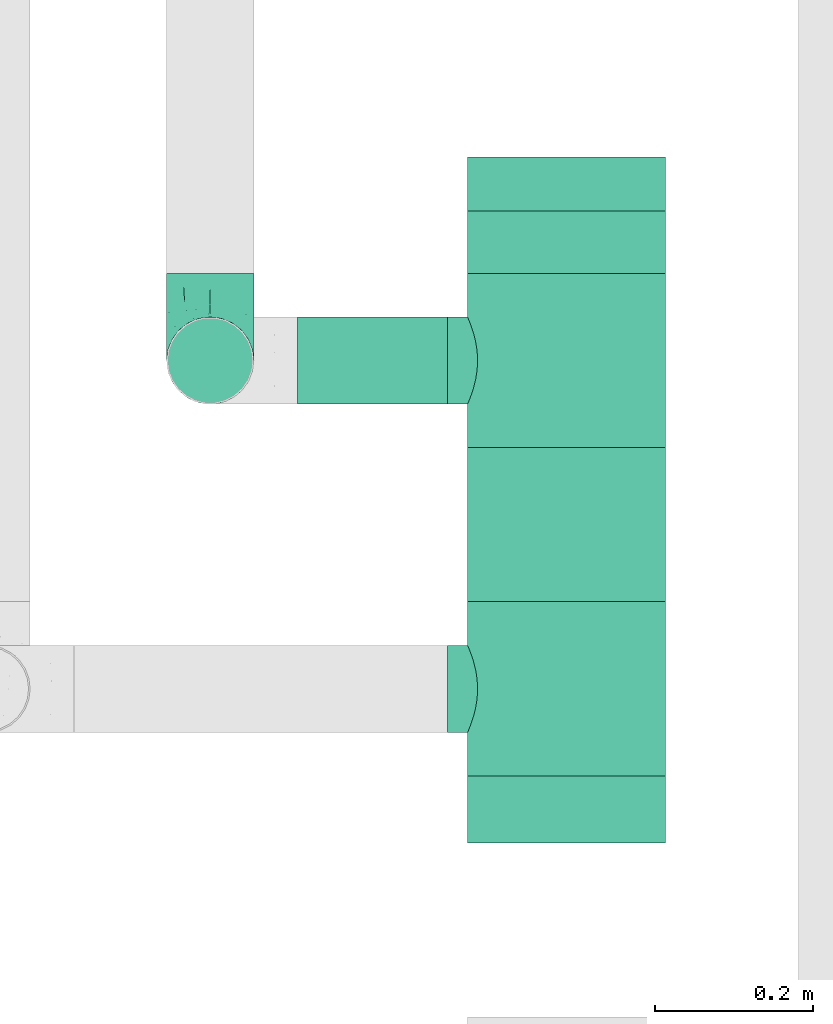
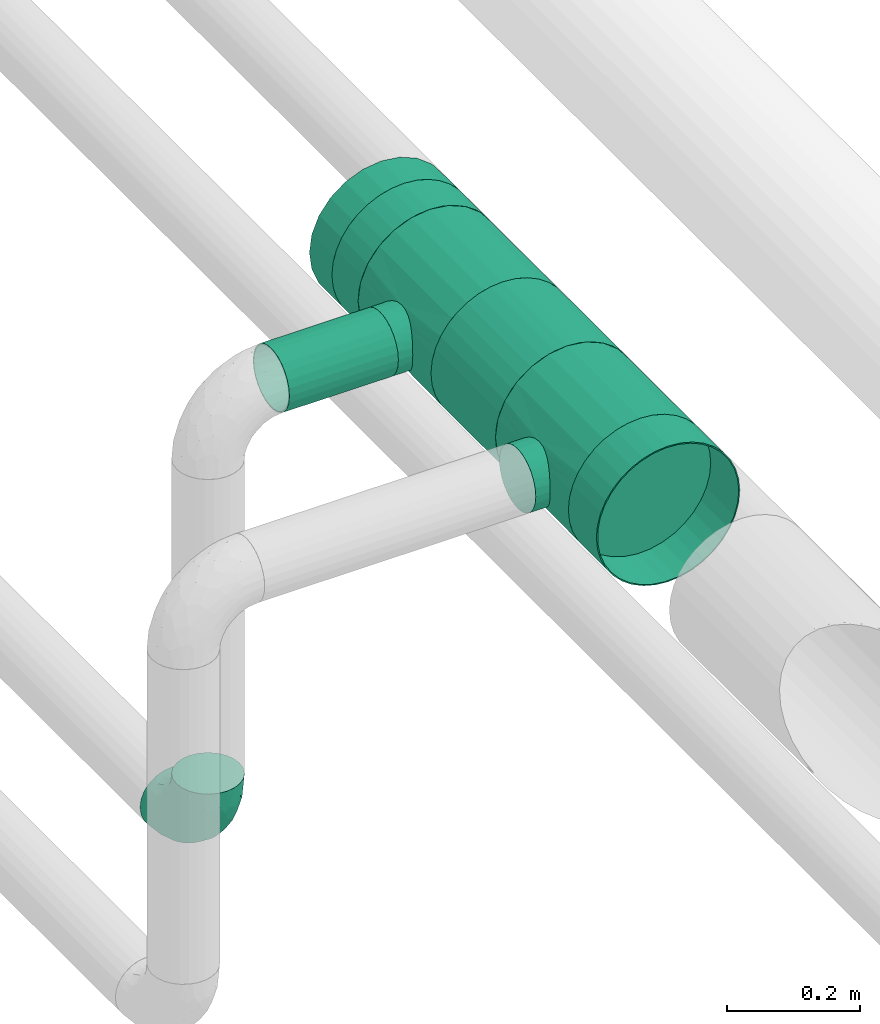
# One storey, part 42 of 91: 4 flow fittings, 4 flow segments.
"""IFC2X3 building model written with IfcOpenShell, lengths in millimetres."""

from ifc_helpers import new_model, entity, si_unit, converted_unit, derived_unit, direction, frame, origin_with_axes, origin_2d_with_axis, place, context, subcontext, project, spatial, hollow_circle, extrude, open_shell, surface_model, source, transform, mapped, material, layer, layer_set, layer_usage, type_object, element, save


model = new_model("IFC2X3")

# Units and contexts
model_context = context("Model", 3, precision=1e-05, world=origin_with_axes(), true_north=direction((0.0, 1.0)))
body_context = subcontext(model_context, "Body", "Model", "MODEL_VIEW")
ifc_project = project(units=[si_unit("AREAUNIT", "SQUARE_METRE"), si_unit("VOLUMEUNIT", "CUBIC_METRE", prefix="DECI"), si_unit("TIMEUNIT", "SECOND"), si_unit("THERMODYNAMICTEMPERATUREUNIT", "DEGREE_CELSIUS"), si_unit("PRESSUREUNIT", "PASCAL"), si_unit("MASSUNIT", "GRAM", prefix="KILO"), si_unit("LENGTHUNIT", "METRE", prefix="MILLI"), si_unit("POWERUNIT", "WATT"), si_unit("ELECTRICCURRENTUNIT", "AMPERE"), si_unit("ELECTRICVOLTAGEUNIT", "VOLT"), derived_unit("VOLUMETRICFLOWRATEUNIT", [(si_unit("VOLUMEUNIT", "CUBIC_METRE", prefix="DECI"), 1), (si_unit("TIMEUNIT", "SECOND"), -1)]), derived_unit("LINEARVELOCITYUNIT", [(si_unit("LENGTHUNIT", "METRE"), 1), (si_unit("TIMEUNIT", "SECOND"), -1)]), derived_unit("MASSDENSITYUNIT", [(si_unit("MASSUNIT", "GRAM", prefix="KILO"), 1), (si_unit("VOLUMEUNIT", "CUBIC_METRE"), -1)]), converted_unit("PLANEANGLEUNIT", "DEGREE", entity("IfcRatioMeasure", 0.01745), si_unit("PLANEANGLEUNIT", "RADIAN"), dimensions=[0, 0, 0, 0, 0, 0, 0])], contexts=[model_context])

# Site, building, storey
site_placement = place(None, origin_with_axes())
site = spatial("IfcSite", under=ifc_project, at=site_placement, CompositionType="ELEMENT")
building_placement = place(site_placement, origin_with_axes())
building = spatial("IfcBuilding", under=site, at=building_placement, Name="mc-building", CompositionType="ELEMENT")
storey_placement = place(building_placement, frame((0.0, 0.0, 8700.0), z_axis=(0.0, 0.0, 1.0), x_axis=(1.0, 0.0, 0.0)))
storey = spatial("IfcBuildingStorey", under=building, at=storey_placement, CompositionType="ELEMENT", Elevation=8700.0)

# Flow fittings
duct_fitting_type_1 = type_object("IfcDuctFittingType", PredefinedType="JUNCTION")
shared_shape_1 = source(origin_with_axes(), body_context, "Body", "SurfaceModel", [
    surface_model("IfcShellBasedSurfaceModel", [(0.0, -150.0, -55.0), (14.23505, -150.0, -53.12592), (-14.23505, -150.0, -53.12592), (-53.12592, -150.0, 14.23505), (-27.5, -150.0, -47.63139), (-47.63139, -150.0, -27.5), (-38.89087, -150.0, -38.89087), (55.0, -150.0, 0.0), (53.12592, -150.0, 14.23505), (38.89087, -150.0, -38.89087), (27.5, -150.0, -47.63139), (53.12592, -150.0, -14.23505), (47.63139, -150.0, -27.5), (-53.12592, -150.0, -14.23505), (-47.63139, -150.0, 27.5), (-38.89087, -150.0, 38.89087), (14.23505, -150.0, 53.12592), (-27.5, -150.0, 47.63139), (-14.23505, -150.0, 53.12592), (47.63139, -150.0, 27.5), (38.89087, -150.0, 38.89087), (27.5, -150.0, 47.63139), (0.0, -150.0, 55.0), (-55.0, -150.0, 0.0), (0.0, -112.24973, 55.0), (-12.37766, -112.9301, 53.58912), (-24.01261, -114.7894, 49.48125), (-34.33641, -117.38394, 42.96523), (-42.94114, -120.18295, 34.36653), (-49.47537, -122.66953, 24.02472), (-53.59142, -124.38666, 12.36769), (-55.0, -125.0, 0.0), (-49.46959, -122.66719, -24.03663), (-42.93393, -120.18037, -34.37554), (-53.588, -124.38519, -12.38248), (-34.32718, -117.38124, -42.9726), (-24.00081, -114.78693, -49.48698), (-12.36238, -112.92842, -53.59265), (0.0, -112.24973, -55.0), (12.37766, -112.9301, -53.58912), (24.01261, -114.7894, -49.48125), (34.33641, -117.38394, -42.96523), (42.94114, -120.18295, -34.36653), (49.47537, -122.66953, -24.02472), (53.59142, -124.38666, -12.36769), (55.0, -125.0, 0.0), (49.47537, -122.66953, 24.02472), (42.94114, -120.18295, 34.36653), (53.59142, -124.38666, 12.36769), (34.33641, -117.38394, 42.96523), (24.01261, -114.7894, 49.48125), (12.37766, -112.9301, 53.58912), (-110.0, 0.0, -125.0), (-110.0, -32.35238, -120.74073), (-110.0, 32.35238, -120.74073), (-110.0, 120.74073, 32.35238), (-110.0, 62.5, -108.25318), (-110.0, 88.38835, -88.38835), (-110.0, 108.25318, -62.5), (-110.0, -125.0, 0.0), (-110.0, -120.74073, 32.35238), (-110.0, -88.38835, -88.38835), (-110.0, -62.5, -108.25318), (-110.0, -120.74073, -32.35238), (-110.0, -108.25318, -62.5), (-110.0, 120.74073, -32.35238), (-110.0, 108.25318, 62.5), (-110.0, 62.5, 108.25318), (-110.0, 32.35238, 120.74073), (-110.0, 88.38835, 88.38835), (-110.0, 0.0, 125.0), (-110.0, -108.25318, 62.5), (-110.0, -88.38835, 88.38835), (-110.0, -32.35238, 120.74073), (-110.0, -62.5, 108.25318), (-110.0, 125.0, 0.0), (110.0, 32.35238, -120.74073), (110.0, 125.0, 0.0), (110.0, 0.0, -125.0), (110.0, 62.5, -108.25318), (110.0, 88.38835, -88.38835), (110.0, 108.25318, -62.5), (110.0, -88.38835, -88.38835), (110.0, -120.74073, 32.35238), (110.0, -62.5, -108.25318), (110.0, -32.35238, -120.74073), (110.0, -108.25318, -62.5), (110.0, -120.74073, -32.35238), (110.0, -125.0, 0.0), (110.0, 120.74073, -32.35238), (110.0, 108.25318, 62.5), (110.0, 120.74073, 32.35238), (110.0, 88.38835, 88.38835), (110.0, 62.5, 108.25318), (110.0, 32.35238, 120.74073), (110.0, -62.5, 108.25318), (110.0, -108.25318, 62.5), (110.0, -88.38835, 88.38835), (110.0, -32.35238, 120.74073), (110.0, 0.0, 125.0), (-110.0, -122.87036, -16.17619), (110.0, -114.49695, -47.42619), (-110.0, -114.49695, -47.42619), (110.0, -122.87036, -16.17619), (110.0, -122.87036, 16.17619), (110.0, -114.49695, 47.42619), (-110.0, -122.87036, 16.17619), (-110.0, -114.49695, 47.42619)], [open_shell([[[0, 1, 2]], [[2, 3, 4]], [[5, 6, 3]], [[6, 4, 3]], [[2, 7, 8]], [[9, 7, 10]], [[1, 10, 7]], [[11, 7, 12]], [[9, 12, 7]], [[7, 2, 1]], [[5, 3, 13]], [[2, 14, 3]], [[2, 15, 14]], [[2, 16, 17]], [[17, 15, 2]], [[16, 18, 17]], [[2, 8, 19]], [[2, 19, 20]], [[2, 20, 21]], [[16, 2, 21]], [[16, 22, 18]], [[23, 13, 3]], [[22, 24, 25]], [[18, 25, 26]], [[22, 25, 18]], [[17, 27, 15]], [[17, 18, 26]], [[27, 17, 26]], [[28, 29, 14]], [[30, 31, 23]], [[29, 30, 3]], [[15, 28, 14]], [[3, 14, 29]], [[23, 3, 30]], [[28, 15, 27]], [[32, 33, 5]], [[34, 32, 13]], [[31, 34, 23]], [[23, 34, 13]], [[32, 5, 13]], [[33, 6, 5]], [[4, 35, 36]], [[36, 37, 2]], [[38, 0, 37]], [[4, 6, 35]], [[2, 4, 36]], [[37, 0, 2]], [[35, 6, 33]], [[0, 38, 39]], [[1, 39, 40]], [[0, 39, 1]], [[10, 41, 9]], [[10, 1, 40]], [[41, 10, 40]], [[42, 43, 12]], [[44, 45, 7]], [[43, 44, 11]], [[9, 42, 12]], [[7, 11, 44]], [[43, 11, 12]], [[42, 9, 41]], [[46, 47, 19]], [[48, 46, 8]], [[45, 48, 7]], [[7, 48, 8]], [[46, 19, 8]], [[47, 20, 19]], [[21, 49, 50]], [[50, 51, 16]], [[24, 22, 51]], [[20, 49, 21]], [[16, 21, 50]], [[22, 16, 51]], [[49, 20, 47]], [[52, 53, 54]], [[54, 55, 56]], [[57, 55, 58]], [[56, 55, 57]], [[54, 59, 60]], [[61, 59, 62]], [[54, 53, 62]], [[63, 59, 64]], [[61, 64, 59]], [[62, 59, 54]], [[65, 58, 55]], [[66, 55, 54]], [[67, 66, 54]], [[67, 54, 68]], [[69, 66, 67]], [[70, 68, 54]], [[60, 71, 54]], [[71, 72, 54]], [[73, 70, 74]], [[72, 74, 70]], [[54, 72, 70]], [[75, 65, 55]], [[76, 77, 78]], [[79, 77, 76]], [[80, 81, 77]], [[80, 77, 79]], [[82, 78, 83]], [[78, 82, 84]], [[84, 85, 78]], [[86, 83, 87]], [[86, 82, 83]], [[88, 87, 83]], [[77, 81, 89]], [[90, 78, 91]], [[78, 90, 92]], [[93, 94, 78]], [[78, 92, 93]], [[95, 78, 94]], [[78, 96, 83]], [[78, 97, 96]], [[94, 98, 95]], [[78, 95, 97]], [[99, 98, 94]], [[78, 77, 91]], [[68, 99, 94]], [[67, 94, 93]], [[70, 99, 68]], [[68, 94, 67]], [[93, 69, 67]], [[93, 92, 69]], [[55, 90, 91]], [[75, 91, 77]], [[92, 66, 69]], [[92, 90, 66]], [[66, 90, 55]], [[91, 75, 55]], [[89, 81, 65]], [[77, 89, 65]], [[65, 75, 77]], [[58, 65, 81]], [[81, 57, 58]], [[81, 80, 57]], [[54, 79, 76]], [[52, 76, 78]], [[80, 56, 57]], [[80, 79, 56]], [[56, 79, 54]], [[76, 52, 54]], [[85, 53, 78]], [[84, 62, 85]], [[82, 86, 38]], [[34, 59, 100]], [[39, 38, 86]], [[40, 101, 41]], [[84, 82, 61]], [[82, 38, 61]], [[85, 62, 53]], [[53, 52, 78]], [[37, 36, 64]], [[33, 102, 35]], [[61, 38, 64]], [[35, 102, 36]], [[61, 62, 84]], [[38, 37, 64]], [[39, 86, 40]], [[101, 42, 41]], [[40, 86, 101]], [[42, 87, 43]], [[88, 45, 44]], [[87, 103, 43]], [[44, 103, 88]], [[43, 103, 44]], [[63, 102, 33]], [[63, 33, 32]], [[102, 64, 36]], [[100, 63, 32]], [[31, 59, 34]], [[100, 32, 34]], [[101, 87, 42]], [[45, 88, 48]], [[104, 83, 46]], [[46, 83, 47]], [[46, 48, 104]], [[47, 83, 105]], [[96, 50, 105]], [[31, 30, 59]], [[59, 30, 106]], [[27, 107, 28]], [[60, 106, 29]], [[60, 29, 28]], [[107, 60, 28]], [[50, 96, 51]], [[50, 49, 105]], [[24, 51, 96]], [[29, 106, 30]], [[95, 98, 73]], [[74, 97, 95]], [[24, 96, 97]], [[70, 98, 99]], [[25, 24, 71]], [[48, 88, 104]], [[71, 107, 26]], [[71, 26, 25]], [[24, 72, 71]], [[26, 107, 27]], [[24, 97, 72]], [[97, 74, 72]], [[73, 74, 95]], [[98, 70, 73]], [[47, 105, 49]]])]),
])
for number, where, z_axis, x_axis in (
    (1, (8419.02679, 10182.03578, 1214.30701), (0.0, 0.0, 1.0), (0.0, -1.0, 0.0)),
    (2, (8419.02679, 10596.38741, 1214.30701), (0.0, 0.0, 1.0), (0.0, -1.0, 0.0)),
):
    element("IfcFlowFitting", number, at=place(storey_placement, frame(where, z_axis=z_axis, x_axis=x_axis)), inside=storey, type_object=duct_fitting_type_1, context=body_context, shape_type="MappedRepresentation", body=[
        mapped(shared_shape_1, transform((0.0, 0.0, 0.0), scale=1.0)),
    ])
duct_fitting_type_2 = type_object("IfcDuctFittingType", Name="BU", PredefinedType="BEND")
shared_shape_2 = source(origin_with_axes(), body_context, "Body", "SurfaceModel", [
    surface_model("IfcShellBasedSurfaceModel", [(-110.0, 0.0, -55.0), (-110.0, -14.23505, -53.12592), (-110.0, 14.23505, -53.12592), (-110.0, 53.12592, 14.23505), (-110.0, 27.5, -47.63139), (-110.0, 38.89087, -38.89087), (-110.0, -55.0, 0.0), (-110.0, -53.12592, 14.23505), (-110.0, -38.89087, -38.89087), (-110.0, -27.5, -47.63139), (-110.0, -53.12592, -14.23505), (-110.0, -47.63139, -27.5), (-110.0, -14.23505, 53.12592), (-110.0, 14.23505, 53.12592), (-110.0, 27.5, 47.63139), (-110.0, -47.63139, 27.5), (-110.0, -38.89087, 38.89087), (-110.0, -27.5, 47.63139), (-110.0, 0.0, 55.0), (-110.0, 55.0, 0.0), (-110.0, 53.12592, -14.23505), (-110.0, 47.63139, -27.5), (-110.0, 47.63139, 27.5), (-110.0, 38.89087, 38.89087), (-14.23505, 110.0, -53.12592), (-55.0, 110.0, 0.0), (0.0, 110.0, -55.0), (-27.5, 110.0, -47.63139), (-38.89087, 110.0, -38.89087), (-47.63139, 110.0, -27.5), (38.89087, 110.0, -38.89087), (53.12592, 110.0, 14.23505), (27.5, 110.0, -47.63139), (14.23505, 110.0, -53.12592), (47.63139, 110.0, -27.5), (53.12592, 110.0, -14.23505), (55.0, 110.0, 0.0), (-53.12592, 110.0, -14.23505), (-53.12592, 110.0, 14.23505), (-47.63139, 110.0, 27.5), (-38.89087, 110.0, 38.89087), (-27.5, 110.0, 47.63139), (0.0, 110.0, 55.0), (-14.23505, 110.0, 53.12592), (38.89087, 110.0, 38.89087), (47.63139, 110.0, 27.5), (27.5, 110.0, 47.63139), (14.23505, 110.0, 53.12592), (-64.21732, 48.68956, 43.63444), (-76.6405, 38.18013, 45.55988), (-60.44912, 32.56953, 51.94617), (-76.00813, 5.38378, 55.0), (-90.15553, 11.94394, 54.09138), (-78.5998, 26.77405, 50.81338), (-70.18771, 18.55163, 54.03432), (-75.55424, 54.2118, 32.41257), (-93.27622, 45.77614, 33.48188), (-96.12334, 22.13664, 50.81337), (-21.00813, 45.34362, 55.0), (-18.36258, 70.48427, 54.04484), (-32.04182, 59.64019, 52.24446), (-63.88653, 74.77858, 17.99134), (-74.66383, 63.08407, 19.92123), (-63.60674, 66.07878, 29.97482), (-99.597, 52.72185, 18.52927), (-93.11138, 56.59448, 10.50359), (-98.21577, 57.34403, 0.0), (-53.42855, 92.60092, 21.04759), (-88.54852, 54.8376, 21.04759), (-11.86161, 90.23965, 54.10313), (-5.38378, 76.00813, 55.0), (-57.34403, 98.21577, 0.0), (-56.64619, 93.12774, 10.22088), (-45.34362, 21.00813, 55.0), (-44.60838, 44.60838, 52.13415), (-92.68484, 35.46673, 43.63443), (-22.25266, 95.40765, 50.81337), (-35.97783, 90.61597, 43.63443), (-43.70931, 69.58671, 44.47149), (-27.23711, 77.39884, 50.81337), (-57.2828, 79.3123, 24.9774), (-58.67786, 84.31125, 16.04456), (-82.93277, 60.36161, 12.91784), (-49.88337, 54.51816, 47.224), (-74.57753, 66.83759, 9.55742), (-45.35812, 94.97281, 33.48188), (-59.18663, 88.95241, 0.0), (-51.517, 78.6292, 33.48188), (-65.14788, 80.03077, 0.0), (-56.45322, 62.06476, 39.63545), (-88.95241, 59.18663, 0.0), (-71.10913, 71.10913, 0.0), (-80.03077, 65.14788, 0.0), (-94.9309, 45.36788, -33.48188), (-93.11358, 56.60141, -10.46614), (-99.64997, 52.79499, -18.30015), (-90.20425, 36.08686, -43.63443), (-79.99933, 46.56772, -37.92748), (-76.00813, 5.38378, -55.0), (-72.75364, 19.68651, -53.60527), (-45.34362, 21.00813, -55.0), (-21.91957, 65.12078, -53.85897), (-5.38378, 76.00813, -55.0), (-21.00813, 45.34362, -55.0), (-35.41876, 92.89265, -43.63443), (-91.10309, 11.02766, -54.21832), (-45.77614, 93.27622, -33.48188), (-90.50474, 23.21022, -50.81337), (-70.92854, 33.31794, -49.51754), (-78.52933, 63.35627, -11.73997), (-24.91508, 84.05606, -50.81337), (-88.78941, 54.74452, -21.04759), (-69.59921, 57.34866, -33.48187), (-73.36422, 62.46673, -22.94182), (-63.49062, 67.59111, -28.46929), (-56.59448, 93.11138, -10.50359), (-54.8376, 88.54852, -21.04759), (-54.10679, 75.85581, -32.31867), (-57.75956, 31.09612, -52.80882), (-52.72185, 99.597, -18.52927), (-12.62913, 89.46304, -53.99097), (-34.46825, 66.46123, -50.04329), (-43.9837, 43.9837, -52.42279), (-65.78527, 72.58348, -17.68796), (-70.34468, 43.65295, -44.21951), (-57.47001, 51.99467, -44.91465), (-60.72547, 82.29174, -12.88567), (-42.34915, 74.24548, -43.63444), (-57.25194, 63.5016, -38.08211), (-80.95344, 53.56991, -29.32027), (-52.32891, 4.55257, -54.0482), (32.52942, 47.13398, -30.48571), (14.88266, 20.92917, -33.7947), (14.95561, 36.05775, -42.26543), (30.24048, 70.09027, -41.7461), (19.3559, 65.35825, -48.00507), (-70.35075, -46.44478, -19.5952), (-47.13398, -32.52942, -30.48571), (-28.49299, -30.5778, -16.4009), (-4.55257, 52.32891, -54.0482), (-22.4954, 22.4954, -53.25347), (-75.47368, -11.22546, -52.60718), (-81.32209, -51.5606, -9.98467), (-80.81763, -41.84862, -32.14655), (-70.09027, -30.24048, -41.7461), (-36.05774, -14.95561, -42.26543), (-9.15831, -10.852, -27.8997), (-65.35825, -19.3559, -48.00507), (11.22546, 75.47368, -52.60718), (3.94376, 43.9333, -50.53315), (-13.39742, 13.39743, -48.13058), (-43.9333, -3.94376, -50.53315), (49.37776, 67.29486, 0.0), (41.8609, 47.82256, -9.92641), (50.20582, 74.51695, -9.9731), (18.93131, 11.7156, -17.56239), (-27.5, -32.89419, 0.0), (-1.23348, -12.25375, -12.18106), (41.84862, 80.81763, -32.14655), (35.70604, 41.31408, -20.38235), (46.44478, 70.35075, -19.5952), (32.89419, 27.5, 0.0), (6.67262, -6.67262, 0.0), (-67.29486, -49.37776, 0.0), (-50.36265, -42.95545, -9.51562), (-5.47251, 5.47251, -39.92906), (-70.35075, -46.44478, 19.5952), (-74.51695, -50.20582, 9.9731), (-41.31407, -35.70604, 20.38235), (-47.13398, -32.52942, 30.48571), (-80.81763, -41.84862, 32.14655), (-4.55257, 52.32891, 54.0482), (11.22546, 75.47368, 52.60718), (-43.9333, -3.94376, 50.53315), (-65.35825, -19.3559, 48.00507), (-36.05774, -14.95561, 42.26543), (-70.09027, -30.24048, 41.7461), (-11.7156, -18.93131, 17.56239), (30.5778, 28.49299, 16.4009), (12.25375, 1.23348, 12.18106), (51.5606, 81.32209, 9.98467), (42.95545, 50.36265, 9.51562), (-75.47368, -11.22546, 52.60718), (-52.32891, 4.55257, 54.0482), (3.94376, 43.9333, 50.53315), (-22.4954, 22.4954, 53.25347), (-13.39742, 13.39743, 48.13058), (10.852, 9.15831, 27.8997), (-20.92916, -14.88266, 33.79469), (-47.82256, -41.8609, 9.92641), (32.52942, 47.13398, 30.48571), (46.44478, 70.35075, 19.5952), (41.84862, 80.81763, 32.14655), (30.24048, 70.09027, 41.7461), (19.3559, 65.35825, 48.00507), (14.95561, 36.05775, 42.26543), (-5.47251, 5.47251, 39.92906)], [open_shell([[[0, 1, 2]], [[2, 3, 4]], [[4, 3, 5]], [[2, 6, 7]], [[8, 6, 9]], [[1, 9, 6]], [[10, 6, 11]], [[8, 11, 6]], [[6, 2, 1]], [[12, 13, 14]], [[15, 2, 7]], [[16, 17, 2]], [[2, 17, 12]], [[12, 18, 13]], [[19, 20, 3]], [[5, 3, 21]], [[20, 21, 3]], [[22, 3, 2]], [[23, 22, 2]], [[12, 14, 2]], [[2, 14, 23]], [[15, 16, 2]], [[24, 25, 26]], [[27, 25, 24]], [[25, 28, 29]], [[28, 25, 27]], [[30, 26, 31]], [[26, 30, 32]], [[32, 33, 26]], [[34, 31, 35]], [[31, 34, 30]], [[35, 31, 36]], [[29, 37, 25]], [[38, 39, 26]], [[39, 40, 26]], [[41, 42, 40]], [[42, 26, 40]], [[42, 41, 43]], [[26, 44, 45]], [[31, 26, 45]], [[26, 46, 44]], [[47, 46, 26]], [[42, 47, 26]], [[25, 38, 26]], [[48, 49, 50]], [[18, 51, 52]], [[53, 54, 50]], [[55, 56, 49]], [[56, 22, 23]], [[13, 57, 14]], [[58, 59, 60]], [[61, 62, 63]], [[3, 64, 65]], [[53, 52, 54]], [[3, 65, 66]], [[67, 39, 38]], [[56, 68, 64]], [[65, 64, 68]], [[69, 59, 70]], [[38, 71, 72]], [[73, 58, 74]], [[75, 49, 56]], [[76, 69, 43]], [[53, 57, 52]], [[77, 78, 79]], [[41, 76, 43]], [[43, 69, 42]], [[55, 68, 56]], [[23, 14, 75]], [[76, 77, 79]], [[80, 67, 81]], [[62, 82, 68]], [[60, 78, 83]], [[62, 84, 82]], [[85, 77, 40]], [[81, 67, 72]], [[86, 72, 71]], [[87, 85, 67]], [[61, 81, 88]], [[77, 41, 40]], [[78, 77, 87]], [[23, 75, 56]], [[83, 89, 48]], [[85, 40, 39]], [[62, 68, 55]], [[89, 87, 63]], [[83, 48, 50]], [[57, 75, 14]], [[49, 75, 53]], [[67, 85, 39]], [[87, 77, 85]], [[63, 62, 55]], [[89, 55, 48]], [[80, 63, 87]], [[66, 65, 90]], [[66, 19, 3]], [[84, 91, 92]], [[92, 90, 82]], [[65, 82, 90]], [[61, 84, 62]], [[92, 82, 84]], [[68, 82, 65]], [[3, 22, 64]], [[56, 64, 22]], [[38, 25, 71]], [[81, 72, 86]], [[38, 72, 67]], [[91, 61, 88]], [[80, 81, 61]], [[63, 80, 61]], [[67, 80, 87]], [[77, 76, 41]], [[79, 59, 69]], [[79, 69, 76]], [[42, 69, 70]], [[60, 59, 79]], [[58, 70, 59]], [[78, 60, 79]], [[58, 60, 74]], [[52, 57, 13]], [[75, 57, 53]], [[18, 52, 13]], [[52, 51, 54]], [[51, 73, 54]], [[50, 73, 74]], [[73, 50, 54]], [[50, 74, 83]], [[60, 83, 74]], [[89, 83, 78]], [[87, 89, 78]], [[55, 89, 63]], [[50, 49, 53]], [[55, 49, 48]], [[81, 86, 88]], [[91, 84, 61]], [[5, 21, 93]], [[90, 94, 66]], [[20, 94, 95]], [[96, 93, 97]], [[98, 99, 100]], [[96, 4, 5]], [[101, 102, 103]], [[28, 27, 104]], [[2, 105, 0]], [[104, 106, 28]], [[99, 105, 107]], [[108, 107, 96]], [[90, 109, 94]], [[107, 2, 4]], [[20, 66, 94]], [[27, 24, 110]], [[109, 111, 94]], [[112, 113, 114]], [[37, 115, 71]], [[116, 106, 117]], [[99, 118, 100]], [[116, 115, 119]], [[37, 119, 115]], [[24, 120, 110]], [[121, 110, 101]], [[119, 106, 116]], [[101, 110, 120]], [[122, 103, 100]], [[117, 123, 116]], [[124, 125, 108]], [[115, 116, 126]], [[106, 29, 28]], [[26, 102, 120]], [[127, 104, 110]], [[97, 124, 96]], [[125, 122, 118]], [[128, 127, 125]], [[96, 5, 93]], [[115, 126, 86]], [[117, 106, 127]], [[111, 113, 129]], [[95, 93, 21]], [[97, 129, 112]], [[110, 104, 27]], [[106, 104, 127]], [[96, 107, 4]], [[99, 107, 108]], [[99, 108, 118]], [[105, 99, 98]], [[112, 114, 128]], [[121, 125, 127]], [[20, 19, 66]], [[109, 90, 92]], [[94, 111, 95]], [[91, 123, 109]], [[129, 113, 112]], [[93, 95, 111]], [[21, 20, 95]], [[71, 115, 86]], [[71, 25, 37]], [[123, 91, 88]], [[126, 116, 123]], [[123, 88, 126]], [[86, 126, 88]], [[37, 29, 119]], [[106, 119, 29]], [[129, 93, 111]], [[124, 112, 125]], [[0, 105, 98]], [[107, 105, 2]], [[125, 118, 108]], [[100, 118, 122]], [[93, 129, 97]], [[113, 111, 109]], [[109, 123, 113]], [[114, 123, 117]], [[123, 114, 113]], [[128, 114, 117]], [[127, 128, 117]], [[112, 128, 125]], [[103, 122, 101]], [[110, 121, 127]], [[101, 122, 121]], [[125, 121, 122]], [[26, 120, 24]], [[101, 120, 102]], [[96, 124, 108]], [[92, 91, 109]], [[112, 124, 97]], [[100, 130, 98]], [[131, 132, 133]], [[32, 134, 135]], [[136, 137, 138]], [[139, 140, 103]], [[98, 141, 0]], [[142, 10, 136]], [[143, 144, 137]], [[6, 10, 142]], [[137, 145, 146]], [[144, 147, 145]], [[143, 136, 11]], [[11, 136, 10]], [[8, 143, 11]], [[148, 149, 139]], [[8, 9, 144]], [[9, 1, 147]], [[130, 141, 98]], [[103, 140, 100]], [[148, 135, 149]], [[150, 151, 140]], [[152, 153, 154]], [[130, 140, 151]], [[148, 26, 33]], [[147, 1, 141]], [[155, 146, 132]], [[156, 138, 157]], [[134, 30, 158]], [[150, 140, 149]], [[158, 30, 34]], [[30, 134, 32]], [[153, 159, 160]], [[131, 160, 159]], [[144, 145, 137]], [[36, 152, 154]], [[146, 138, 137]], [[155, 161, 162]], [[158, 160, 131]], [[133, 149, 135]], [[156, 163, 164]], [[163, 142, 164]], [[139, 103, 102]], [[153, 152, 161]], [[34, 35, 160]], [[162, 157, 155]], [[132, 165, 133]], [[157, 146, 155]], [[140, 130, 100]], [[141, 130, 151]], [[141, 151, 147]], [[141, 1, 0]], [[102, 26, 148]], [[140, 139, 149]], [[102, 148, 139]], [[135, 33, 32]], [[151, 150, 145]], [[9, 147, 144]], [[151, 145, 147]], [[145, 165, 146]], [[135, 148, 33]], [[133, 135, 134]], [[131, 133, 134]], [[133, 165, 150]], [[133, 150, 149]], [[145, 150, 165]], [[132, 131, 159]], [[146, 165, 132]], [[160, 158, 34]], [[134, 158, 131]], [[144, 143, 8]], [[136, 143, 137]], [[155, 153, 161]], [[154, 153, 160]], [[153, 155, 159]], [[132, 159, 155]], [[160, 35, 154]], [[36, 154, 35]], [[164, 136, 138]], [[6, 142, 163]], [[136, 164, 142]], [[156, 164, 138]], [[156, 157, 162]], [[146, 157, 138]], [[15, 7, 166]], [[6, 163, 167]], [[168, 169, 166]], [[166, 169, 170]], [[171, 172, 70]], [[173, 174, 175]], [[17, 176, 174]], [[177, 156, 162]], [[176, 16, 170]], [[170, 16, 15]], [[161, 178, 179]], [[152, 180, 181]], [[182, 173, 183]], [[18, 12, 182]], [[184, 185, 186]], [[183, 185, 73]], [[183, 73, 51]], [[177, 187, 188]], [[189, 168, 166]], [[187, 178, 190]], [[16, 176, 17]], [[161, 152, 181]], [[45, 191, 31]], [[45, 44, 192]], [[192, 191, 45]], [[180, 36, 31]], [[193, 194, 195]], [[46, 47, 194]], [[193, 195, 190]], [[193, 44, 46]], [[172, 42, 70]], [[185, 58, 73]], [[189, 163, 156]], [[163, 189, 167]], [[70, 58, 171]], [[184, 171, 185]], [[169, 188, 175]], [[180, 31, 191]], [[192, 193, 190]], [[191, 190, 178]], [[182, 174, 173]], [[194, 47, 172]], [[190, 195, 187]], [[186, 185, 173]], [[162, 179, 177]], [[188, 196, 175]], [[179, 187, 177]], [[185, 171, 58]], [[172, 171, 184]], [[172, 184, 194]], [[172, 47, 42]], [[51, 18, 182]], [[185, 183, 173]], [[51, 182, 183]], [[174, 12, 17]], [[184, 186, 195]], [[46, 194, 193]], [[184, 195, 194]], [[195, 196, 187]], [[174, 182, 12]], [[175, 174, 176]], [[169, 175, 176]], [[175, 196, 186]], [[175, 186, 173]], [[195, 186, 196]], [[188, 169, 168]], [[187, 196, 188]], [[166, 170, 15]], [[176, 170, 169]], [[193, 192, 44]], [[191, 192, 190]], [[177, 189, 156]], [[167, 189, 166]], [[189, 177, 168]], [[188, 168, 177]], [[166, 7, 167]], [[6, 167, 7]], [[181, 191, 178]], [[36, 180, 152]], [[191, 181, 180]], [[161, 181, 178]], [[161, 179, 162]], [[187, 179, 178]]])]),
])
flow_fitting_1_placement = place(storey_placement, frame((7969.21808, 10596.38741, 415.0), z_axis=(-1.0, 0.0, 0.0), x_axis=(0.0, -1.0, 0.0)))
element("IfcFlowFitting", 3, at=flow_fitting_1_placement, inside=storey, type_object=duct_fitting_type_2, Name="BU", context=body_context, shape_type="MappedRepresentation", body=[
    mapped(shared_shape_2, transform((0.0, 0.0, 0.0), scale=1.0)),
])
duct_fitting_type_3 = type_object("IfcDuctFittingType", Name="EPF", PredefinedType="OBSTRUCTION")
shared_shape_3 = source(origin_with_axes(), body_context, "Body", "SurfaceModel", [
    surface_model("IfcShellBasedSurfaceModel", [(0.0, 62.5, -108.25318), (0.0, 32.35238, -120.74073), (0.0, 0.0, -125.0), (0.0, 88.38835, -88.38835), (0.0, 120.74073, -32.35238), (0.0, 108.25318, -62.5), (0.0, -62.5, 108.25318), (0.0, -120.74073, -32.35238), (0.0, -88.38835, -88.38835), (0.0, -108.25318, -62.5), (0.0, -62.5, -108.25318), (0.0, -32.35238, -120.74073), (0.0, -125.0, 0.0), (0.0, -120.74073, 32.35238), (0.0, 125.0, 0.0), (0.0, 108.25318, 62.5), (0.0, 120.74073, 32.35238), (0.0, 88.38835, 88.38835), (0.0, 62.5, 108.25318), (0.0, 32.35238, 120.74073), (0.0, 0.0, 125.0), (0.0, -108.25318, 62.5), (0.0, -88.38835, 88.38835), (0.0, -32.35238, 120.74073), (68.0, 32.35238, -120.74073), (68.0, 62.5, 108.25318), (68.0, 0.0, -125.0), (68.0, 88.38835, -88.38835), (68.0, 62.5, -108.25318), (68.0, 108.25318, -62.5), (68.0, 120.74073, -32.35238), (68.0, -32.35238, -120.74073), (68.0, 32.35238, 120.74073), (68.0, -62.5, -108.25318), (68.0, -108.25318, -62.5), (68.0, -88.38835, -88.38835), (68.0, -125.0, 0.0), (68.0, -120.74073, -32.35238), (68.0, 120.74073, 32.35238), (68.0, 108.25318, 62.5), (68.0, 88.38835, 88.38835), (68.0, -32.35238, 120.74073), (68.0, -108.25318, 62.5), (68.0, -120.74073, 32.35238), (68.0, -88.38835, 88.38835), (68.0, -62.5, 108.25318), (68.0, 0.0, 125.0), (68.0, 125.0, 0.0)], [open_shell([[[0, 1, 2]], [[3, 0, 2]], [[2, 4, 5]], [[3, 2, 5]], [[6, 2, 7]], [[8, 9, 10]], [[2, 11, 10]], [[10, 9, 2]], [[2, 9, 7]], [[12, 13, 7]], [[4, 2, 14]], [[15, 16, 14]], [[17, 15, 14]], [[18, 2, 19]], [[18, 17, 2]], [[2, 20, 19]], [[7, 21, 22]], [[21, 7, 13]], [[23, 20, 6]], [[7, 22, 6]], [[6, 20, 2]], [[2, 17, 14]], [[24, 25, 26]], [[27, 24, 28]], [[29, 30, 24]], [[29, 24, 27]], [[31, 26, 32]], [[33, 34, 35]], [[36, 33, 31]], [[34, 36, 37]], [[36, 34, 33]], [[36, 31, 32]], [[30, 25, 24]], [[38, 39, 30]], [[40, 30, 39]], [[32, 26, 25]], [[30, 40, 25]], [[41, 36, 32]], [[42, 43, 36]], [[44, 42, 36]], [[45, 44, 36]], [[45, 36, 41]], [[32, 46, 41]], [[38, 30, 47]], [[20, 46, 32]], [[19, 32, 25]], [[20, 32, 19]], [[17, 25, 40]], [[18, 19, 25]], [[25, 17, 18]], [[16, 39, 38]], [[14, 38, 47]], [[17, 39, 15]], [[15, 39, 16]], [[38, 14, 16]], [[39, 17, 40]], [[14, 47, 30]], [[4, 30, 29]], [[14, 30, 4]], [[3, 29, 27]], [[5, 4, 29]], [[29, 3, 5]], [[1, 28, 24]], [[2, 24, 26]], [[3, 28, 0]], [[0, 28, 1]], [[24, 2, 1]], [[28, 3, 27]], [[2, 26, 31]], [[11, 31, 33]], [[2, 31, 11]], [[8, 33, 35]], [[10, 11, 33]], [[33, 8, 10]], [[7, 34, 37]], [[12, 37, 36]], [[8, 34, 9]], [[9, 34, 7]], [[37, 12, 7]], [[34, 8, 35]], [[12, 36, 43]], [[13, 43, 42]], [[12, 43, 13]], [[22, 42, 44]], [[21, 13, 42]], [[42, 22, 21]], [[23, 45, 41]], [[20, 41, 46]], [[22, 45, 6]], [[6, 45, 23]], [[41, 20, 23]], [[45, 22, 44]]])]),
])
flow_fitting_2_placement = place(storey_placement, frame((8419.02679, 10785.18604, 1214.30701), z_axis=(0.0, 0.0, 1.0), x_axis=(0.0, 1.0, 0.0)))
element("IfcFlowFitting", 4, at=flow_fitting_2_placement, inside=storey, type_object=duct_fitting_type_3, context=body_context, shape_type="MappedRepresentation", body=[
    mapped(shared_shape_3, transform((0.0, 0.0, 0.0), scale=1.0)),
])

# Flow segments
ifc_material = material(Name="FZ1")
ifc_layer = layer(ifc_material, 0.0)
ifc_layer_set = layer_set([ifc_layer], Name="FZ1")
ifc_layer_usage = layer_usage(ifc_layer_set, "AXIS1", "POSITIVE", 0.0)
duct_segment_type_1 = type_object("IfcDuctSegmentType", Name="Safe", PredefinedType="RIGIDSEGMENT")
shared_shape_4 = source(origin_with_axes(), body_context, "Body", "SweptSolid", [
    extrude(hollow_circle(Radius=125.0, WallThickness=2.0, at=origin_2d_with_axis()), frame((0.0, 0.0, 0.0), z_axis=(1.0, 0.0, 0.0), x_axis=(0.0, 1.0, 0.0)), (0.0, 0.0, 1.0), 194.4),
])
flow_segment_1_placement = place(storey_placement, frame((8419.02679, 10292.03578, 1214.30701), z_axis=(0.0, 0.0, 1.0), x_axis=(0.0, 1.0, 0.0)))
element("IfcFlowSegment", 5, at=flow_segment_1_placement, inside=storey, type_object=duct_segment_type_1, material=ifc_layer_usage, Name="Safe", context=body_context, shape_type="MappedRepresentation", body=[
    mapped(shared_shape_4, transform((0.0, 0.0, 0.0), scale=1.0)),
])
shared_shape_5 = source(origin_with_axes(), body_context, "Body", "SweptSolid", [
    extrude(hollow_circle(Radius=125.0, WallThickness=2.0, at=origin_2d_with_axis()), frame((0.0, 0.0, 0.0), z_axis=(1.0, 0.0, 0.0), x_axis=(0.0, 1.0, 0.0)), (0.0, 0.0, 1.0), 84.4),
])
flow_segment_2_placement = place(storey_placement, frame((8419.02679, 10072.03578, 1214.30701), z_axis=(0.0, 0.0, 1.0), x_axis=(0.0, -1.0, 0.0)))
element("IfcFlowSegment", 6, at=flow_segment_2_placement, inside=storey, type_object=duct_segment_type_1, material=ifc_layer_usage, Name="Safe", context=body_context, shape_type="MappedRepresentation", body=[
    mapped(shared_shape_5, transform((0.0, 0.0, 0.0), scale=1.0)),
])
duct_segment_type_2 = type_object("IfcDuctSegmentType", PredefinedType="RIGIDSEGMENT")
shared_shape_6 = source(origin_with_axes(), body_context, "Body", "SweptSolid", [
    extrude(hollow_circle(Radius=55.0, WallThickness=2.0, at=origin_2d_with_axis()), frame((0.0, 0.0, 0.0), z_axis=(1.0, 0.0, 0.0), x_axis=(0.0, 1.0, 0.0)), (0.0, 0.0, 1.0), 189.8),
])
flow_segment_3_placement = place(storey_placement, frame((8269.02679, 10596.38741, 1214.30701), z_axis=(0.0, 0.0, 1.0), x_axis=(-1.0, 0.0, 0.0)))
element("IfcFlowSegment", 7, at=flow_segment_3_placement, inside=storey, type_object=duct_segment_type_2, material=ifc_layer_usage, context=body_context, shape_type="MappedRepresentation", body=[
    mapped(shared_shape_6, transform((0.0, 0.0, 0.0), scale=1.0)),
])
shared_shape_7 = source(origin_with_axes(), body_context, "Body", "SweptSolid", [
    extrude(hollow_circle(Radius=125.0, WallThickness=2.0, at=origin_2d_with_axis()), frame((0.0, 0.0, 0.0), z_axis=(1.0, 0.0, 0.0), x_axis=(0.0, 1.0, 0.0)), (0.0, 0.0, 1.0), 78.8),
])
flow_segment_4_placement = place(storey_placement, frame((8419.02679, 10706.38741, 1214.30701), z_axis=(0.0, 0.0, 1.0), x_axis=(0.0, 1.0, 0.0)))
element("IfcFlowSegment", 8, at=flow_segment_4_placement, inside=storey, type_object=duct_segment_type_1, material=ifc_layer_usage, Name="Safe", context=body_context, shape_type="MappedRepresentation", body=[
    mapped(shared_shape_7, transform((0.0, 0.0, 0.0), scale=1.0)),
])

save(model, "model.ifc")
